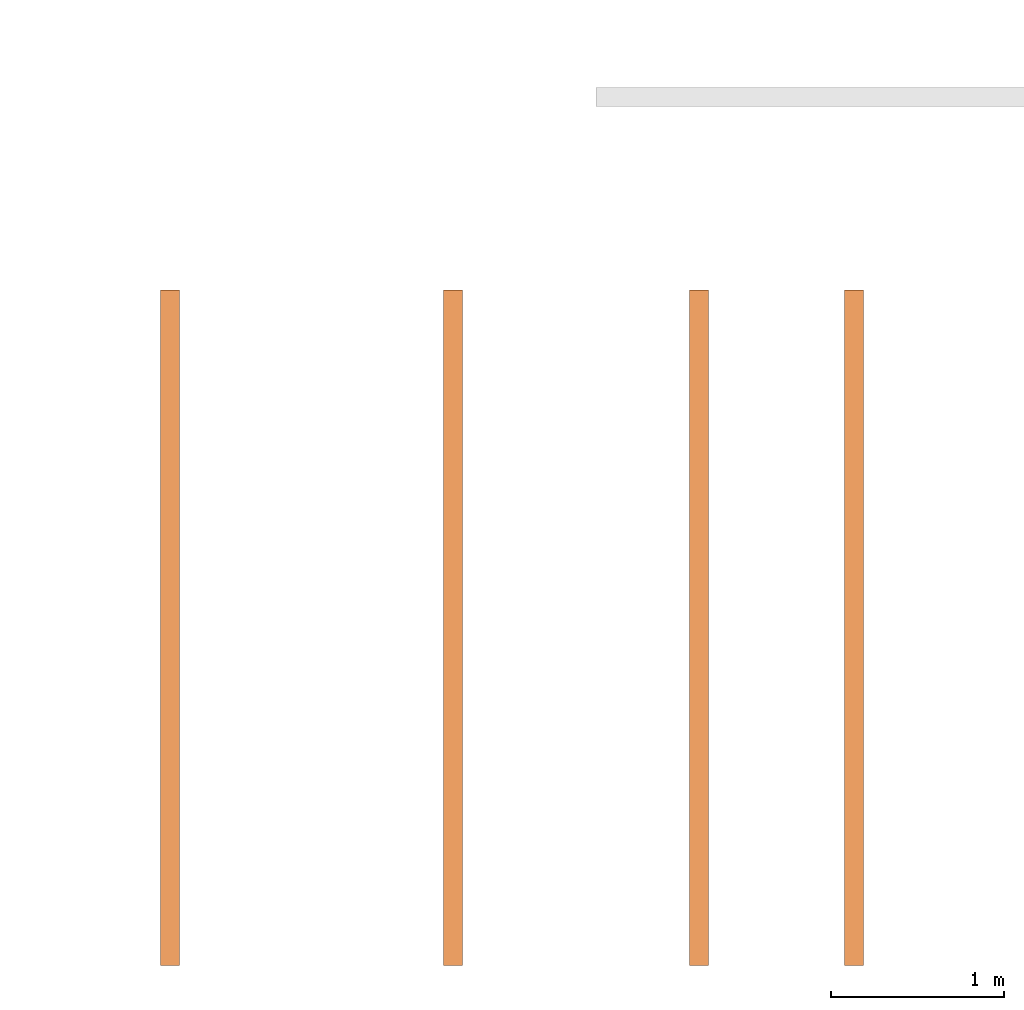
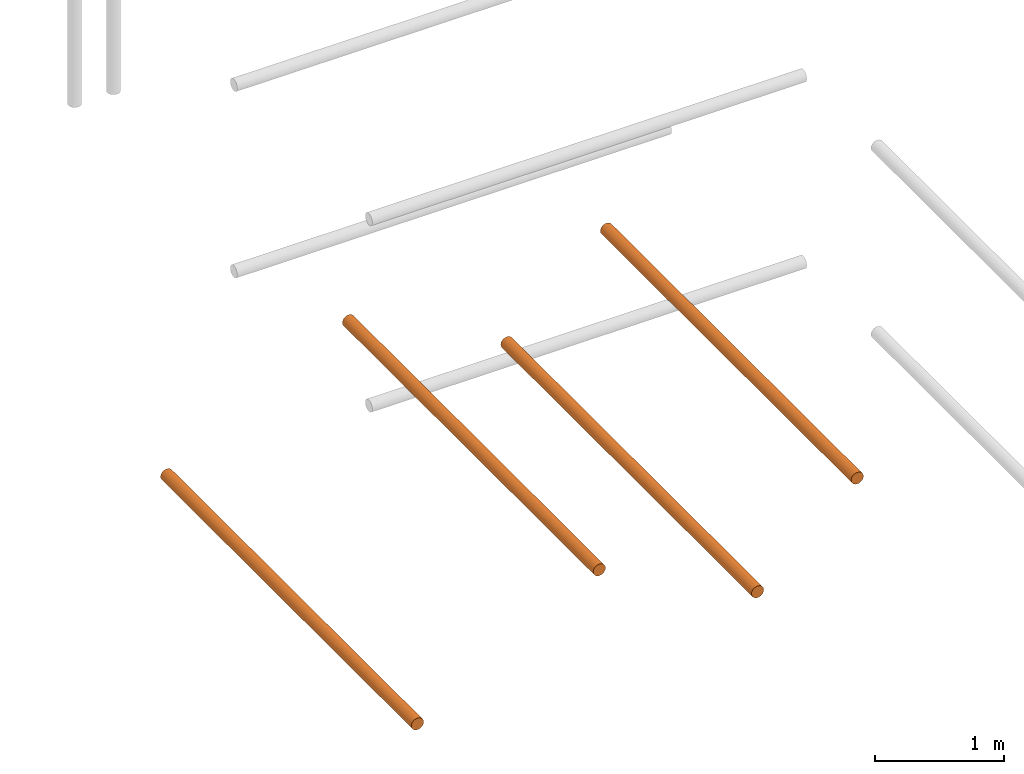
# One storey, part 1 of 5: 4 proxies.
"""IFC2X3 building model written with IfcOpenShell, lengths in metres."""

from ifc_helpers import new_model, entity, si_unit, converted_unit, frame, origin, place, context, subcontext, project, spatial, faceted_brep, material, element, save


model = new_model("IFC2X3")

# Units and contexts
model_context = context("Model", 3, precision=1e-05, world=origin())
body_context = subcontext(model_context, "Body", "Model", "MODEL_VIEW")
ifc_project = project(units=[si_unit("LENGTHUNIT", "METRE"), si_unit("AREAUNIT", "SQUARE_METRE"), si_unit("VOLUMEUNIT", "CUBIC_METRE"), converted_unit("PLANEANGLEUNIT", "DEGREE", entity("IfcPlaneAngleMeasure", 0.0174532925199433), si_unit("PLANEANGLEUNIT", "RADIAN"), dimensions=[0, 0, 0, 0, 0, 0, 0])], contexts=[model_context])

# Site, building, storey
site_placement = place(None, frame((2.0, 7.0, 6.0)))
site = spatial("IfcSite", under=ifc_project, at=site_placement, CompositionType="ELEMENT")
building_placement = place(site_placement, origin())
building = spatial("IfcBuilding", under=site, at=building_placement, Name="de", CompositionType="ELEMENT")
storey_placement = place(building_placement, frame((0.0, 0.0, 4.0)))
storey = spatial("IfcBuildingStorey", under=building, at=storey_placement, CompositionType="ELEMENT", Elevation=4.0)

# Proxies
ifc_material_1 = material()
proxy_1_placement = place(storey_placement, frame((-2.374125779134114, 2.273736754432321e-16, 2.835069238362357)))
element("IfcBuildingElementProxy", 1, at=proxy_1_placement, inside=storey, material=ifc_material_1, context=body_context, shape_type="Brep", body=[
    faceted_brep([(0.11, 0.0, 0.05500000000000001), (0.1081259204458988, 0.0, 0.04076495251936138), (0.1026313972081441, 0.0, 0.02750000000000001), (0.09389087296526015, 0.0, 0.01610912703473991), (0.08250000000000002, 0.0, 0.007368602791855885), (0.06923504748063866, 0.0, 0.00187407955410125), (0.05500000000000003, 0.0, 0.0), (0.0407649525193614, 0.0, 0.001874079554101236), (0.02750000000000004, 0.0, 0.007368602791855849), (0.01610912703473991, 0.0, 0.01610912703473987), (0.007368602791855913, 0.0, 0.02749999999999994), (0.001874079554101257, 0.0, 0.04076495251936132), (0.0, 0.0, 0.05499999999999995), (0.001874079554101236, 0.0, 0.06923504748063862), (0.007368602791855849, 0.0, 0.08249999999999996), (0.01610912703473984, 0.0, 0.09389087296526008), (0.02749999999999994, 0.0, 0.1026313972081441), (0.04076495251936132, 0.0, 0.1081259204458988), (0.055, 0.0, 0.11), (0.06923504748063865, 0.0, 0.1081259204458988), (0.0825, 0.0, 0.1026313972081441), (0.09389087296526012, 0.0, 0.09389087296526012), (0.1026313972081441, 0.0, 0.0825), (0.1081259204458988, 0.0, 0.06923504748063866), (0.11, 3.9, 0.055), (0.1081259204458988, 3.9, 0.06923504748063866), (0.1026313972081441, 3.9, 0.0825), (0.09389087296526012, 3.9, 0.09389087296526012), (0.0825, 3.9, 0.1026313972081441), (0.06923504748063865, 3.9, 0.1081259204458988), (0.055, 3.9, 0.11), (0.04076495251936132, 3.9, 0.1081259204458988), (0.02749999999999994, 3.9, 0.1026313972081441), (0.01610912703473984, 3.9, 0.09389087296526008), (0.007368602791855849, 3.9, 0.08249999999999996), (0.001874079554101236, 3.9, 0.06923504748063862), (0.0, 3.9, 0.05499999999999995), (0.001874079554101257, 3.9, 0.04076495251936132), (0.007368602791855913, 3.9, 0.02749999999999994), (0.01610912703473991, 3.9, 0.01610912703473987), (0.02750000000000004, 3.9, 0.007368602791855849), (0.0407649525193614, 3.9, 0.001874079554101236), (0.05500000000000003, 3.9, 0.0), (0.06923504748063866, 3.9, 0.00187407955410125), (0.08250000000000002, 3.9, 0.007368602791855885), (0.09389087296526015, 3.9, 0.01610912703473991), (0.1026313972081441, 3.9, 0.02750000000000001), (0.1081259204458988, 3.9, 0.04076495251936138), (0.055, 3.9, 0.11), (0.055, 0.0, 0.11), (0.04076495251936132, 0.0, 0.1081259204458988), (0.04076495251936132, 3.9, 0.1081259204458988), (0.04076495251936132, 3.9, 0.1081259204458988), (0.04076495251936132, 0.0, 0.1081259204458988), (0.02749999999999994, 0.0, 0.1026313972081441), (0.02749999999999994, 3.9, 0.1026313972081441), (0.02749999999999994, 3.9, 0.1026313972081441), (0.02749999999999994, 0.0, 0.1026313972081441), (0.01610912703473984, 0.0, 0.09389087296526008), (0.01610912703473984, 3.9, 0.09389087296526008), (0.01610912703473984, 3.9, 0.09389087296526008), (0.01610912703473984, 0.0, 0.09389087296526008), (0.007368602791855849, 0.0, 0.08249999999999996), (0.007368602791855849, 3.9, 0.08249999999999996), (0.007368602791855849, 3.9, 0.08249999999999996), (0.007368602791855849, 0.0, 0.08249999999999996), (0.001874079554101236, 0.0, 0.06923504748063862), (0.001874079554101236, 3.9, 0.06923504748063862), (0.001874079554101236, 3.9, 0.06923504748063862), (0.001874079554101236, 0.0, 0.06923504748063862), (0.0, 0.0, 0.05499999999999995), (0.0, 3.9, 0.05499999999999995), (0.0, 3.9, 0.05499999999999995), (0.0, 0.0, 0.05499999999999995), (0.001874079554101257, 0.0, 0.04076495251936132), (0.001874079554101257, 3.9, 0.04076495251936132), (0.001874079554101257, 3.9, 0.04076495251936132), (0.001874079554101257, 0.0, 0.04076495251936132), (0.007368602791855913, 0.0, 0.02749999999999994), (0.007368602791855913, 3.9, 0.02749999999999994), (0.007368602791855913, 3.9, 0.02749999999999994), (0.007368602791855913, 0.0, 0.02749999999999994), (0.01610912703473991, 0.0, 0.01610912703473987), (0.01610912703473991, 3.9, 0.01610912703473987), (0.01610912703473991, 3.9, 0.01610912703473987), (0.01610912703473991, 0.0, 0.01610912703473987), (0.02750000000000004, 0.0, 0.007368602791855849), (0.02750000000000004, 3.9, 0.007368602791855849), (0.02750000000000004, 3.9, 0.007368602791855849), (0.02750000000000004, 0.0, 0.007368602791855849), (0.0407649525193614, 0.0, 0.001874079554101236), (0.0407649525193614, 3.9, 0.001874079554101236), (0.0407649525193614, 3.9, 0.001874079554101236), (0.0407649525193614, 0.0, 0.001874079554101236), (0.05500000000000003, 0.0, 0.0), (0.05500000000000003, 3.9, 0.0), (0.05500000000000003, 3.9, 0.0), (0.05500000000000003, 0.0, 0.0), (0.06923504748063866, 0.0, 0.00187407955410125), (0.06923504748063866, 3.9, 0.00187407955410125), (0.06923504748063866, 3.9, 0.00187407955410125), (0.06923504748063866, 0.0, 0.00187407955410125), (0.08250000000000002, 0.0, 0.007368602791855885), (0.08250000000000002, 3.9, 0.007368602791855885), (0.08250000000000002, 3.9, 0.007368602791855885), (0.08250000000000002, 0.0, 0.007368602791855885), (0.09389087296526015, 0.0, 0.01610912703473991), (0.09389087296526015, 3.9, 0.01610912703473991), (0.09389087296526015, 3.9, 0.01610912703473991), (0.09389087296526015, 0.0, 0.01610912703473991), (0.1026313972081441, 0.0, 0.02750000000000001), (0.1026313972081441, 3.9, 0.02750000000000001), (0.1026313972081441, 3.9, 0.02750000000000001), (0.1026313972081441, 0.0, 0.02750000000000001), (0.1081259204458988, 0.0, 0.04076495251936138), (0.1081259204458988, 3.9, 0.04076495251936138), (0.1081259204458988, 3.9, 0.04076495251936138), (0.1081259204458988, 0.0, 0.04076495251936138), (0.11, 0.0, 0.05500000000000001), (0.11, 3.9, 0.055), (0.11, 3.9, 0.055), (0.11, 0.0, 0.05500000000000001), (0.1081259204458988, 0.0, 0.06923504748063866), (0.1081259204458988, 3.9, 0.06923504748063866), (0.1081259204458988, 3.9, 0.06923504748063866), (0.1081259204458988, 0.0, 0.06923504748063866), (0.1026313972081441, 0.0, 0.0825), (0.1026313972081441, 3.9, 0.0825), (0.1026313972081441, 3.9, 0.0825), (0.1026313972081441, 0.0, 0.0825), (0.09389087296526012, 0.0, 0.09389087296526012), (0.09389087296526012, 3.9, 0.09389087296526012), (0.09389087296526012, 3.9, 0.09389087296526012), (0.09389087296526012, 0.0, 0.09389087296526012), (0.0825, 0.0, 0.1026313972081441), (0.0825, 3.9, 0.1026313972081441), (0.0825, 3.9, 0.1026313972081441), (0.0825, 0.0, 0.1026313972081441), (0.06923504748063865, 0.0, 0.1081259204458988), (0.06923504748063865, 3.9, 0.1081259204458988), (0.06923504748063865, 3.9, 0.1081259204458988), (0.06923504748063865, 0.0, 0.1081259204458988), (0.055, 0.0, 0.11), (0.055, 3.9, 0.11)], [[[0, 1, 2, 3, 4, 5, 6, 7, 8, 9, 10, 11, 12, 13, 14, 15, 16, 17, 18, 19, 20, 21, 22, 23]], [[24, 25, 26, 27, 28, 29, 30, 31, 32, 33, 34, 35, 36, 37, 38, 39, 40, 41, 42, 43, 44, 45, 46, 47]], [[48, 49, 50, 51]], [[52, 53, 54, 55]], [[56, 57, 58, 59]], [[60, 61, 62, 63]], [[64, 65, 66, 67]], [[68, 69, 70, 71]], [[72, 73, 74, 75]], [[76, 77, 78, 79]], [[80, 81, 82, 83]], [[84, 85, 86, 87]], [[88, 89, 90, 91]], [[92, 93, 94, 95]], [[96, 97, 98, 99]], [[100, 101, 102, 103]], [[104, 105, 106, 107]], [[108, 109, 110, 111]], [[112, 113, 114, 115]], [[116, 117, 118, 119]], [[120, 121, 122, 123]], [[124, 125, 126, 127]], [[128, 129, 130, 131]], [[132, 133, 134, 135]], [[136, 137, 138, 139]], [[140, 141, 142, 143]]], orient=[[False], [False], [False], [False], [False], [False], [False], [False], [False], [False], [False], [False], [False], [False], [False], [False], [False], [False], [False], [False], [False], [False], [False], [False], [False], [False]]),
])
ifc_material_2 = material()
proxy_2_placement = place(storey_placement, frame((-0.05837989678116958, 2.273736754432321e-16, 2.894702179538829)))
element("IfcBuildingElementProxy", 2, at=proxy_2_placement, inside=storey, material=ifc_material_2, context=body_context, shape_type="Brep", body=[
    faceted_brep([(0.11, 0.0, 0.05500000000000001), (0.1081259204458988, 0.0, 0.04076495251936138), (0.1026313972081441, 0.0, 0.02750000000000001), (0.09389087296526015, 0.0, 0.01610912703473991), (0.08250000000000002, 0.0, 0.007368602791855885), (0.06923504748063866, 0.0, 0.00187407955410125), (0.05500000000000003, 0.0, 0.0), (0.0407649525193614, 0.0, 0.001874079554101236), (0.02750000000000004, 0.0, 0.007368602791855849), (0.01610912703473991, 0.0, 0.01610912703473987), (0.007368602791855913, 0.0, 0.02749999999999994), (0.001874079554101257, 0.0, 0.04076495251936132), (0.0, 0.0, 0.05499999999999995), (0.001874079554101236, 0.0, 0.06923504748063862), (0.007368602791855849, 0.0, 0.08249999999999996), (0.01610912703473984, 0.0, 0.09389087296526008), (0.02749999999999994, 0.0, 0.1026313972081441), (0.04076495251936132, 0.0, 0.1081259204458988), (0.055, 0.0, 0.11), (0.06923504748063865, 0.0, 0.1081259204458988), (0.0825, 0.0, 0.1026313972081441), (0.09389087296526012, 0.0, 0.09389087296526012), (0.1026313972081441, 0.0, 0.0825), (0.1081259204458988, 0.0, 0.06923504748063866), (0.11, 3.9, 0.055), (0.1081259204458988, 3.9, 0.06923504748063866), (0.1026313972081441, 3.9, 0.0825), (0.09389087296526012, 3.9, 0.09389087296526012), (0.0825, 3.9, 0.1026313972081441), (0.06923504748063865, 3.9, 0.1081259204458988), (0.055, 3.9, 0.11), (0.04076495251936132, 3.9, 0.1081259204458988), (0.02749999999999994, 3.9, 0.1026313972081441), (0.01610912703473984, 3.9, 0.09389087296526008), (0.007368602791855849, 3.9, 0.08249999999999996), (0.001874079554101236, 3.9, 0.06923504748063862), (0.0, 3.9, 0.05499999999999995), (0.001874079554101257, 3.9, 0.04076495251936132), (0.007368602791855913, 3.9, 0.02749999999999994), (0.01610912703473991, 3.9, 0.01610912703473987), (0.02750000000000004, 3.9, 0.007368602791855849), (0.0407649525193614, 3.9, 0.001874079554101236), (0.05500000000000003, 3.9, 0.0), (0.06923504748063866, 3.9, 0.00187407955410125), (0.08250000000000002, 3.9, 0.007368602791855885), (0.09389087296526015, 3.9, 0.01610912703473991), (0.1026313972081441, 3.9, 0.02750000000000001), (0.1081259204458988, 3.9, 0.04076495251936138), (0.055, 3.9, 0.11), (0.055, 0.0, 0.11), (0.04076495251936132, 0.0, 0.1081259204458988), (0.04076495251936132, 3.9, 0.1081259204458988), (0.04076495251936132, 3.9, 0.1081259204458988), (0.04076495251936132, 0.0, 0.1081259204458988), (0.02749999999999994, 0.0, 0.1026313972081441), (0.02749999999999994, 3.9, 0.1026313972081441), (0.02749999999999994, 3.9, 0.1026313972081441), (0.02749999999999994, 0.0, 0.1026313972081441), (0.01610912703473984, 0.0, 0.09389087296526008), (0.01610912703473984, 3.9, 0.09389087296526008), (0.01610912703473984, 3.9, 0.09389087296526008), (0.01610912703473984, 0.0, 0.09389087296526008), (0.007368602791855849, 0.0, 0.08249999999999996), (0.007368602791855849, 3.9, 0.08249999999999996), (0.007368602791855849, 3.9, 0.08249999999999996), (0.007368602791855849, 0.0, 0.08249999999999996), (0.001874079554101236, 0.0, 0.06923504748063862), (0.001874079554101236, 3.9, 0.06923504748063862), (0.001874079554101236, 3.9, 0.06923504748063862), (0.001874079554101236, 0.0, 0.06923504748063862), (0.0, 0.0, 0.05499999999999995), (0.0, 3.9, 0.05499999999999995), (0.0, 3.9, 0.05499999999999995), (0.0, 0.0, 0.05499999999999995), (0.001874079554101257, 0.0, 0.04076495251936132), (0.001874079554101257, 3.9, 0.04076495251936132), (0.001874079554101257, 3.9, 0.04076495251936132), (0.001874079554101257, 0.0, 0.04076495251936132), (0.007368602791855913, 0.0, 0.02749999999999994), (0.007368602791855913, 3.9, 0.02749999999999994), (0.007368602791855913, 3.9, 0.02749999999999994), (0.007368602791855913, 0.0, 0.02749999999999994), (0.01610912703473991, 0.0, 0.01610912703473987), (0.01610912703473991, 3.9, 0.01610912703473987), (0.01610912703473991, 3.9, 0.01610912703473987), (0.01610912703473991, 0.0, 0.01610912703473987), (0.02750000000000004, 0.0, 0.007368602791855849), (0.02750000000000004, 3.9, 0.007368602791855849), (0.02750000000000004, 3.9, 0.007368602791855849), (0.02750000000000004, 0.0, 0.007368602791855849), (0.0407649525193614, 0.0, 0.001874079554101236), (0.0407649525193614, 3.9, 0.001874079554101236), (0.0407649525193614, 3.9, 0.001874079554101236), (0.0407649525193614, 0.0, 0.001874079554101236), (0.05500000000000003, 0.0, 0.0), (0.05500000000000003, 3.9, 0.0), (0.05500000000000003, 3.9, 0.0), (0.05500000000000003, 0.0, 0.0), (0.06923504748063866, 0.0, 0.00187407955410125), (0.06923504748063866, 3.9, 0.00187407955410125), (0.06923504748063866, 3.9, 0.00187407955410125), (0.06923504748063866, 0.0, 0.00187407955410125), (0.08250000000000002, 0.0, 0.007368602791855885), (0.08250000000000002, 3.9, 0.007368602791855885), (0.08250000000000002, 3.9, 0.007368602791855885), (0.08250000000000002, 0.0, 0.007368602791855885), (0.09389087296526015, 0.0, 0.01610912703473991), (0.09389087296526015, 3.9, 0.01610912703473991), (0.09389087296526015, 3.9, 0.01610912703473991), (0.09389087296526015, 0.0, 0.01610912703473991), (0.1026313972081441, 0.0, 0.02750000000000001), (0.1026313972081441, 3.9, 0.02750000000000001), (0.1026313972081441, 3.9, 0.02750000000000001), (0.1026313972081441, 0.0, 0.02750000000000001), (0.1081259204458988, 0.0, 0.04076495251936138), (0.1081259204458988, 3.9, 0.04076495251936138), (0.1081259204458988, 3.9, 0.04076495251936138), (0.1081259204458988, 0.0, 0.04076495251936138), (0.11, 0.0, 0.05500000000000001), (0.11, 3.9, 0.055), (0.11, 3.9, 0.055), (0.11, 0.0, 0.05500000000000001), (0.1081259204458988, 0.0, 0.06923504748063866), (0.1081259204458988, 3.9, 0.06923504748063866), (0.1081259204458988, 3.9, 0.06923504748063866), (0.1081259204458988, 0.0, 0.06923504748063866), (0.1026313972081441, 0.0, 0.0825), (0.1026313972081441, 3.9, 0.0825), (0.1026313972081441, 3.9, 0.0825), (0.1026313972081441, 0.0, 0.0825), (0.09389087296526012, 0.0, 0.09389087296526012), (0.09389087296526012, 3.9, 0.09389087296526012), (0.09389087296526012, 3.9, 0.09389087296526012), (0.09389087296526012, 0.0, 0.09389087296526012), (0.0825, 0.0, 0.1026313972081441), (0.0825, 3.9, 0.1026313972081441), (0.0825, 3.9, 0.1026313972081441), (0.0825, 0.0, 0.1026313972081441), (0.06923504748063865, 0.0, 0.1081259204458988), (0.06923504748063865, 3.9, 0.1081259204458988), (0.06923504748063865, 3.9, 0.1081259204458988), (0.06923504748063865, 0.0, 0.1081259204458988), (0.055, 0.0, 0.11), (0.055, 3.9, 0.11)], [[[0, 1, 2, 3, 4, 5, 6, 7, 8, 9, 10, 11, 12, 13, 14, 15, 16, 17, 18, 19, 20, 21, 22, 23]], [[24, 25, 26, 27, 28, 29, 30, 31, 32, 33, 34, 35, 36, 37, 38, 39, 40, 41, 42, 43, 44, 45, 46, 47]], [[48, 49, 50, 51]], [[52, 53, 54, 55]], [[56, 57, 58, 59]], [[60, 61, 62, 63]], [[64, 65, 66, 67]], [[68, 69, 70, 71]], [[72, 73, 74, 75]], [[76, 77, 78, 79]], [[80, 81, 82, 83]], [[84, 85, 86, 87]], [[88, 89, 90, 91]], [[92, 93, 94, 95]], [[96, 97, 98, 99]], [[100, 101, 102, 103]], [[104, 105, 106, 107]], [[108, 109, 110, 111]], [[112, 113, 114, 115]], [[116, 117, 118, 119]], [[120, 121, 122, 123]], [[124, 125, 126, 127]], [[128, 129, 130, 131]], [[132, 133, 134, 135]], [[136, 137, 138, 139]], [[140, 141, 142, 143]]], orient=[[False], [False], [False], [False], [False], [False], [False], [False], [False], [False], [False], [False], [False], [False], [False], [False], [False], [False], [False], [False], [False], [False], [False], [False], [False], [False]]),
])
ifc_material_3 = material()
proxy_3_placement = place(storey_placement, frame((-4.0065625, 2.273736754432321e-16, 1.945)))
element("IfcBuildingElementProxy", 3, at=proxy_3_placement, inside=storey, material=ifc_material_3, context=body_context, shape_type="Brep", body=[
    faceted_brep([(0.11, 0.0, 0.05500000000000001), (0.1081259204458988, 0.0, 0.04076495251936138), (0.1026313972081441, 0.0, 0.02750000000000001), (0.09389087296526015, 0.0, 0.01610912703473991), (0.08250000000000002, 0.0, 0.007368602791855885), (0.06923504748063866, 0.0, 0.00187407955410125), (0.05500000000000003, 0.0, 0.0), (0.0407649525193614, 0.0, 0.001874079554101236), (0.02750000000000004, 0.0, 0.007368602791855849), (0.01610912703473991, 0.0, 0.01610912703473987), (0.007368602791855913, 0.0, 0.02749999999999994), (0.001874079554101257, 0.0, 0.04076495251936132), (0.0, 0.0, 0.05499999999999995), (0.001874079554101236, 0.0, 0.06923504748063862), (0.007368602791855849, 0.0, 0.08249999999999996), (0.01610912703473984, 0.0, 0.09389087296526008), (0.02749999999999994, 0.0, 0.1026313972081441), (0.04076495251936132, 0.0, 0.1081259204458988), (0.055, 0.0, 0.11), (0.06923504748063865, 0.0, 0.1081259204458988), (0.0825, 0.0, 0.1026313972081441), (0.09389087296526012, 0.0, 0.09389087296526012), (0.1026313972081441, 0.0, 0.0825), (0.1081259204458988, 0.0, 0.06923504748063866), (0.11, 3.9, 0.055), (0.1081259204458988, 3.9, 0.06923504748063866), (0.1026313972081441, 3.9, 0.0825), (0.09389087296526012, 3.9, 0.09389087296526012), (0.0825, 3.9, 0.1026313972081441), (0.06923504748063865, 3.9, 0.1081259204458988), (0.055, 3.9, 0.11), (0.04076495251936132, 3.9, 0.1081259204458988), (0.02749999999999994, 3.9, 0.1026313972081441), (0.01610912703473984, 3.9, 0.09389087296526008), (0.007368602791855849, 3.9, 0.08249999999999996), (0.001874079554101236, 3.9, 0.06923504748063862), (0.0, 3.9, 0.05499999999999995), (0.001874079554101257, 3.9, 0.04076495251936132), (0.007368602791855913, 3.9, 0.02749999999999994), (0.01610912703473991, 3.9, 0.01610912703473987), (0.02750000000000004, 3.9, 0.007368602791855849), (0.0407649525193614, 3.9, 0.001874079554101236), (0.05500000000000003, 3.9, 0.0), (0.06923504748063866, 3.9, 0.00187407955410125), (0.08250000000000002, 3.9, 0.007368602791855885), (0.09389087296526015, 3.9, 0.01610912703473991), (0.1026313972081441, 3.9, 0.02750000000000001), (0.1081259204458988, 3.9, 0.04076495251936138), (0.055, 3.9, 0.11), (0.055, 0.0, 0.11), (0.04076495251936132, 0.0, 0.1081259204458988), (0.04076495251936132, 3.9, 0.1081259204458988), (0.04076495251936132, 3.9, 0.1081259204458988), (0.04076495251936132, 0.0, 0.1081259204458988), (0.02749999999999994, 0.0, 0.1026313972081441), (0.02749999999999994, 3.9, 0.1026313972081441), (0.02749999999999994, 3.9, 0.1026313972081441), (0.02749999999999994, 0.0, 0.1026313972081441), (0.01610912703473984, 0.0, 0.09389087296526008), (0.01610912703473984, 3.9, 0.09389087296526008), (0.01610912703473984, 3.9, 0.09389087296526008), (0.01610912703473984, 0.0, 0.09389087296526008), (0.007368602791855849, 0.0, 0.08249999999999996), (0.007368602791855849, 3.9, 0.08249999999999996), (0.007368602791855849, 3.9, 0.08249999999999996), (0.007368602791855849, 0.0, 0.08249999999999996), (0.001874079554101236, 0.0, 0.06923504748063862), (0.001874079554101236, 3.9, 0.06923504748063862), (0.001874079554101236, 3.9, 0.06923504748063862), (0.001874079554101236, 0.0, 0.06923504748063862), (0.0, 0.0, 0.05499999999999995), (0.0, 3.9, 0.05499999999999995), (0.0, 3.9, 0.05499999999999995), (0.0, 0.0, 0.05499999999999995), (0.001874079554101257, 0.0, 0.04076495251936132), (0.001874079554101257, 3.9, 0.04076495251936132), (0.001874079554101257, 3.9, 0.04076495251936132), (0.001874079554101257, 0.0, 0.04076495251936132), (0.007368602791855913, 0.0, 0.02749999999999994), (0.007368602791855913, 3.9, 0.02749999999999994), (0.007368602791855913, 3.9, 0.02749999999999994), (0.007368602791855913, 0.0, 0.02749999999999994), (0.01610912703473991, 0.0, 0.01610912703473987), (0.01610912703473991, 3.9, 0.01610912703473987), (0.01610912703473991, 3.9, 0.01610912703473987), (0.01610912703473991, 0.0, 0.01610912703473987), (0.02750000000000004, 0.0, 0.007368602791855849), (0.02750000000000004, 3.9, 0.007368602791855849), (0.02750000000000004, 3.9, 0.007368602791855849), (0.02750000000000004, 0.0, 0.007368602791855849), (0.0407649525193614, 0.0, 0.001874079554101236), (0.0407649525193614, 3.9, 0.001874079554101236), (0.0407649525193614, 3.9, 0.001874079554101236), (0.0407649525193614, 0.0, 0.001874079554101236), (0.05500000000000003, 0.0, 0.0), (0.05500000000000003, 3.9, 0.0), (0.05500000000000003, 3.9, 0.0), (0.05500000000000003, 0.0, 0.0), (0.06923504748063866, 0.0, 0.00187407955410125), (0.06923504748063866, 3.9, 0.00187407955410125), (0.06923504748063866, 3.9, 0.00187407955410125), (0.06923504748063866, 0.0, 0.00187407955410125), (0.08250000000000002, 0.0, 0.007368602791855885), (0.08250000000000002, 3.9, 0.007368602791855885), (0.08250000000000002, 3.9, 0.007368602791855885), (0.08250000000000002, 0.0, 0.007368602791855885), (0.09389087296526015, 0.0, 0.01610912703473991), (0.09389087296526015, 3.9, 0.01610912703473991), (0.09389087296526015, 3.9, 0.01610912703473991), (0.09389087296526015, 0.0, 0.01610912703473991), (0.1026313972081441, 0.0, 0.02750000000000001), (0.1026313972081441, 3.9, 0.02750000000000001), (0.1026313972081441, 3.9, 0.02750000000000001), (0.1026313972081441, 0.0, 0.02750000000000001), (0.1081259204458988, 0.0, 0.04076495251936138), (0.1081259204458988, 3.9, 0.04076495251936138), (0.1081259204458988, 3.9, 0.04076495251936138), (0.1081259204458988, 0.0, 0.04076495251936138), (0.11, 0.0, 0.05500000000000001), (0.11, 3.9, 0.055), (0.11, 3.9, 0.055), (0.11, 0.0, 0.05500000000000001), (0.1081259204458988, 0.0, 0.06923504748063866), (0.1081259204458988, 3.9, 0.06923504748063866), (0.1081259204458988, 3.9, 0.06923504748063866), (0.1081259204458988, 0.0, 0.06923504748063866), (0.1026313972081441, 0.0, 0.0825), (0.1026313972081441, 3.9, 0.0825), (0.1026313972081441, 3.9, 0.0825), (0.1026313972081441, 0.0, 0.0825), (0.09389087296526012, 0.0, 0.09389087296526012), (0.09389087296526012, 3.9, 0.09389087296526012), (0.09389087296526012, 3.9, 0.09389087296526012), (0.09389087296526012, 0.0, 0.09389087296526012), (0.0825, 0.0, 0.1026313972081441), (0.0825, 3.9, 0.1026313972081441), (0.0825, 3.9, 0.1026313972081441), (0.0825, 0.0, 0.1026313972081441), (0.06923504748063865, 0.0, 0.1081259204458988), (0.06923504748063865, 3.9, 0.1081259204458988), (0.06923504748063865, 3.9, 0.1081259204458988), (0.06923504748063865, 0.0, 0.1081259204458988), (0.055, 0.0, 0.11), (0.055, 3.9, 0.11)], [[[0, 1, 2, 3, 4, 5, 6, 7, 8, 9, 10, 11, 12, 13, 14, 15, 16, 17, 18, 19, 20, 21, 22, 23]], [[24, 25, 26, 27, 28, 29, 30, 31, 32, 33, 34, 35, 36, 37, 38, 39, 40, 41, 42, 43, 44, 45, 46, 47]], [[48, 49, 50, 51]], [[52, 53, 54, 55]], [[56, 57, 58, 59]], [[60, 61, 62, 63]], [[64, 65, 66, 67]], [[68, 69, 70, 71]], [[72, 73, 74, 75]], [[76, 77, 78, 79]], [[80, 81, 82, 83]], [[84, 85, 86, 87]], [[88, 89, 90, 91]], [[92, 93, 94, 95]], [[96, 97, 98, 99]], [[100, 101, 102, 103]], [[104, 105, 106, 107]], [[108, 109, 110, 111]], [[112, 113, 114, 115]], [[116, 117, 118, 119]], [[120, 121, 122, 123]], [[124, 125, 126, 127]], [[128, 129, 130, 131]], [[132, 133, 134, 135]], [[136, 137, 138, 139]], [[140, 141, 142, 143]]], orient=[[False], [False], [False], [False], [False], [False], [False], [False], [False], [False], [False], [False], [False], [False], [False], [False], [False], [False], [False], [False], [False], [False], [False], [False], [False], [False]]),
])
ifc_material_4 = material()
proxy_4_placement = place(storey_placement, frame((-0.9528740144282297, 2.273736754432321e-16, 2.129412767774121)))
element("IfcBuildingElementProxy", 4, at=proxy_4_placement, inside=storey, material=ifc_material_4, context=body_context, shape_type="Brep", body=[
    faceted_brep([(0.11, 0.0, 0.05500000000000001), (0.1081259204458988, 0.0, 0.04076495251936138), (0.1026313972081441, 0.0, 0.02750000000000001), (0.09389087296526015, 0.0, 0.01610912703473991), (0.08250000000000002, 0.0, 0.007368602791855885), (0.06923504748063866, 0.0, 0.00187407955410125), (0.05500000000000003, 0.0, 0.0), (0.0407649525193614, 0.0, 0.001874079554101236), (0.02750000000000004, 0.0, 0.007368602791855849), (0.01610912703473991, 0.0, 0.01610912703473987), (0.007368602791855913, 0.0, 0.02749999999999994), (0.001874079554101257, 0.0, 0.04076495251936132), (0.0, 0.0, 0.05499999999999995), (0.001874079554101236, 0.0, 0.06923504748063862), (0.007368602791855849, 0.0, 0.08249999999999996), (0.01610912703473984, 0.0, 0.09389087296526008), (0.02749999999999994, 0.0, 0.1026313972081441), (0.04076495251936132, 0.0, 0.1081259204458988), (0.055, 0.0, 0.11), (0.06923504748063865, 0.0, 0.1081259204458988), (0.0825, 0.0, 0.1026313972081441), (0.09389087296526012, 0.0, 0.09389087296526012), (0.1026313972081441, 0.0, 0.0825), (0.1081259204458988, 0.0, 0.06923504748063866), (0.11, 3.9, 0.055), (0.1081259204458988, 3.9, 0.06923504748063866), (0.1026313972081441, 3.9, 0.0825), (0.09389087296526012, 3.9, 0.09389087296526012), (0.0825, 3.9, 0.1026313972081441), (0.06923504748063865, 3.9, 0.1081259204458988), (0.055, 3.9, 0.11), (0.04076495251936132, 3.9, 0.1081259204458988), (0.02749999999999994, 3.9, 0.1026313972081441), (0.01610912703473984, 3.9, 0.09389087296526008), (0.007368602791855849, 3.9, 0.08249999999999996), (0.001874079554101236, 3.9, 0.06923504748063862), (0.0, 3.9, 0.05499999999999995), (0.001874079554101257, 3.9, 0.04076495251936132), (0.007368602791855913, 3.9, 0.02749999999999994), (0.01610912703473991, 3.9, 0.01610912703473987), (0.02750000000000004, 3.9, 0.007368602791855849), (0.0407649525193614, 3.9, 0.001874079554101236), (0.05500000000000003, 3.9, 0.0), (0.06923504748063866, 3.9, 0.00187407955410125), (0.08250000000000002, 3.9, 0.007368602791855885), (0.09389087296526015, 3.9, 0.01610912703473991), (0.1026313972081441, 3.9, 0.02750000000000001), (0.1081259204458988, 3.9, 0.04076495251936138), (0.055, 3.9, 0.11), (0.055, 0.0, 0.11), (0.04076495251936132, 0.0, 0.1081259204458988), (0.04076495251936132, 3.9, 0.1081259204458988), (0.04076495251936132, 3.9, 0.1081259204458988), (0.04076495251936132, 0.0, 0.1081259204458988), (0.02749999999999994, 0.0, 0.1026313972081441), (0.02749999999999994, 3.9, 0.1026313972081441), (0.02749999999999994, 3.9, 0.1026313972081441), (0.02749999999999994, 0.0, 0.1026313972081441), (0.01610912703473984, 0.0, 0.09389087296526008), (0.01610912703473984, 3.9, 0.09389087296526008), (0.01610912703473984, 3.9, 0.09389087296526008), (0.01610912703473984, 0.0, 0.09389087296526008), (0.007368602791855849, 0.0, 0.08249999999999996), (0.007368602791855849, 3.9, 0.08249999999999996), (0.007368602791855849, 3.9, 0.08249999999999996), (0.007368602791855849, 0.0, 0.08249999999999996), (0.001874079554101236, 0.0, 0.06923504748063862), (0.001874079554101236, 3.9, 0.06923504748063862), (0.001874079554101236, 3.9, 0.06923504748063862), (0.001874079554101236, 0.0, 0.06923504748063862), (0.0, 0.0, 0.05499999999999995), (0.0, 3.9, 0.05499999999999995), (0.0, 3.9, 0.05499999999999995), (0.0, 0.0, 0.05499999999999995), (0.001874079554101257, 0.0, 0.04076495251936132), (0.001874079554101257, 3.9, 0.04076495251936132), (0.001874079554101257, 3.9, 0.04076495251936132), (0.001874079554101257, 0.0, 0.04076495251936132), (0.007368602791855913, 0.0, 0.02749999999999994), (0.007368602791855913, 3.9, 0.02749999999999994), (0.007368602791855913, 3.9, 0.02749999999999994), (0.007368602791855913, 0.0, 0.02749999999999994), (0.01610912703473991, 0.0, 0.01610912703473987), (0.01610912703473991, 3.9, 0.01610912703473987), (0.01610912703473991, 3.9, 0.01610912703473987), (0.01610912703473991, 0.0, 0.01610912703473987), (0.02750000000000004, 0.0, 0.007368602791855849), (0.02750000000000004, 3.9, 0.007368602791855849), (0.02750000000000004, 3.9, 0.007368602791855849), (0.02750000000000004, 0.0, 0.007368602791855849), (0.0407649525193614, 0.0, 0.001874079554101236), (0.0407649525193614, 3.9, 0.001874079554101236), (0.0407649525193614, 3.9, 0.001874079554101236), (0.0407649525193614, 0.0, 0.001874079554101236), (0.05500000000000003, 0.0, 0.0), (0.05500000000000003, 3.9, 0.0), (0.05500000000000003, 3.9, 0.0), (0.05500000000000003, 0.0, 0.0), (0.06923504748063866, 0.0, 0.00187407955410125), (0.06923504748063866, 3.9, 0.00187407955410125), (0.06923504748063866, 3.9, 0.00187407955410125), (0.06923504748063866, 0.0, 0.00187407955410125), (0.08250000000000002, 0.0, 0.007368602791855885), (0.08250000000000002, 3.9, 0.007368602791855885), (0.08250000000000002, 3.9, 0.007368602791855885), (0.08250000000000002, 0.0, 0.007368602791855885), (0.09389087296526015, 0.0, 0.01610912703473991), (0.09389087296526015, 3.9, 0.01610912703473991), (0.09389087296526015, 3.9, 0.01610912703473991), (0.09389087296526015, 0.0, 0.01610912703473991), (0.1026313972081441, 0.0, 0.02750000000000001), (0.1026313972081441, 3.9, 0.02750000000000001), (0.1026313972081441, 3.9, 0.02750000000000001), (0.1026313972081441, 0.0, 0.02750000000000001), (0.1081259204458988, 0.0, 0.04076495251936138), (0.1081259204458988, 3.9, 0.04076495251936138), (0.1081259204458988, 3.9, 0.04076495251936138), (0.1081259204458988, 0.0, 0.04076495251936138), (0.11, 0.0, 0.05500000000000001), (0.11, 3.9, 0.055), (0.11, 3.9, 0.055), (0.11, 0.0, 0.05500000000000001), (0.1081259204458988, 0.0, 0.06923504748063866), (0.1081259204458988, 3.9, 0.06923504748063866), (0.1081259204458988, 3.9, 0.06923504748063866), (0.1081259204458988, 0.0, 0.06923504748063866), (0.1026313972081441, 0.0, 0.0825), (0.1026313972081441, 3.9, 0.0825), (0.1026313972081441, 3.9, 0.0825), (0.1026313972081441, 0.0, 0.0825), (0.09389087296526012, 0.0, 0.09389087296526012), (0.09389087296526012, 3.9, 0.09389087296526012), (0.09389087296526012, 3.9, 0.09389087296526012), (0.09389087296526012, 0.0, 0.09389087296526012), (0.0825, 0.0, 0.1026313972081441), (0.0825, 3.9, 0.1026313972081441), (0.0825, 3.9, 0.1026313972081441), (0.0825, 0.0, 0.1026313972081441), (0.06923504748063865, 0.0, 0.1081259204458988), (0.06923504748063865, 3.9, 0.1081259204458988), (0.06923504748063865, 3.9, 0.1081259204458988), (0.06923504748063865, 0.0, 0.1081259204458988), (0.055, 0.0, 0.11), (0.055, 3.9, 0.11)], [[[0, 1, 2, 3, 4, 5, 6, 7, 8, 9, 10, 11, 12, 13, 14, 15, 16, 17, 18, 19, 20, 21, 22, 23]], [[24, 25, 26, 27, 28, 29, 30, 31, 32, 33, 34, 35, 36, 37, 38, 39, 40, 41, 42, 43, 44, 45, 46, 47]], [[48, 49, 50, 51]], [[52, 53, 54, 55]], [[56, 57, 58, 59]], [[60, 61, 62, 63]], [[64, 65, 66, 67]], [[68, 69, 70, 71]], [[72, 73, 74, 75]], [[76, 77, 78, 79]], [[80, 81, 82, 83]], [[84, 85, 86, 87]], [[88, 89, 90, 91]], [[92, 93, 94, 95]], [[96, 97, 98, 99]], [[100, 101, 102, 103]], [[104, 105, 106, 107]], [[108, 109, 110, 111]], [[112, 113, 114, 115]], [[116, 117, 118, 119]], [[120, 121, 122, 123]], [[124, 125, 126, 127]], [[128, 129, 130, 131]], [[132, 133, 134, 135]], [[136, 137, 138, 139]], [[140, 141, 142, 143]]], orient=[[False], [False], [False], [False], [False], [False], [False], [False], [False], [False], [False], [False], [False], [False], [False], [False], [False], [False], [False], [False], [False], [False], [False], [False], [False], [False]]),
])

save(model, "model.ifc")
